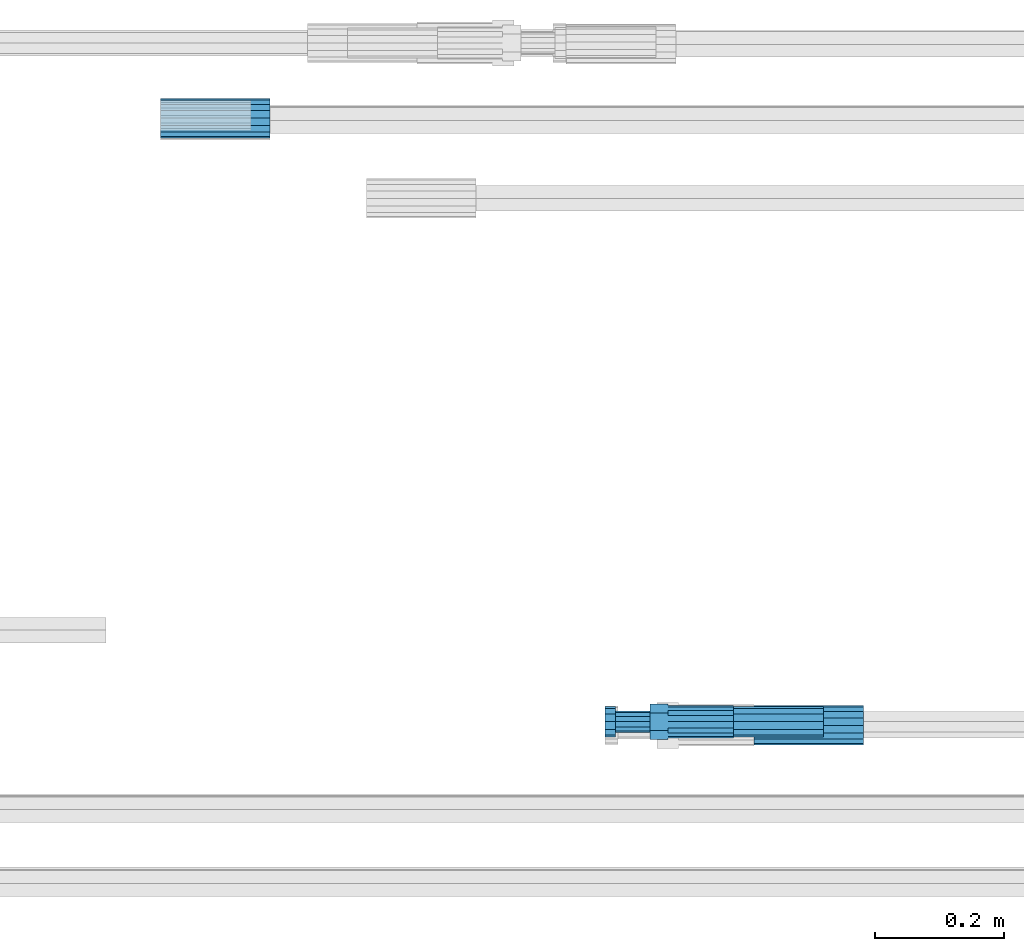
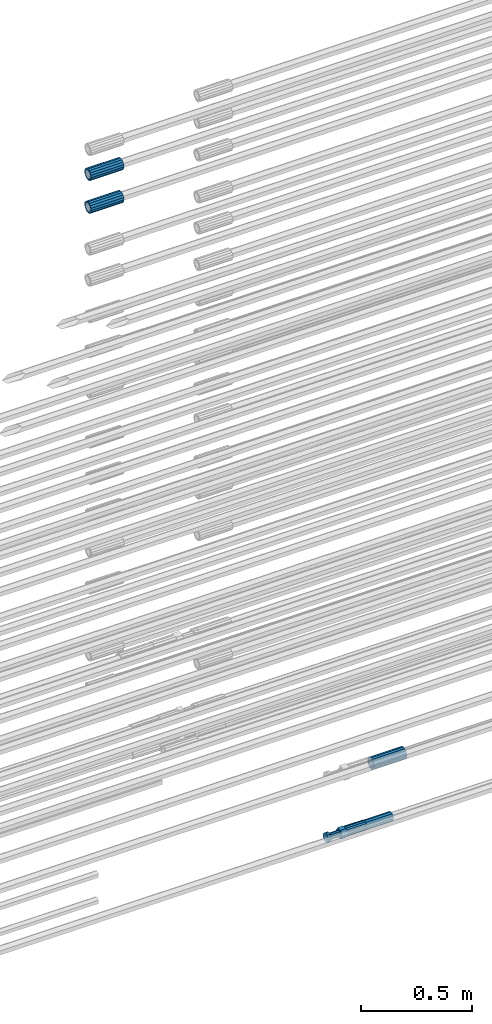
# One storey, part 10 of 119: 5 beams.
"""IFC2X3 building model written with IfcOpenShell, lengths in millimetres."""

from ifc_helpers import new_model, si_unit, frame, origin_with_axes, place, context, subcontext, project, spatial, faceted_brep, material, type_object, element, save


model = new_model("IFC2X3")

# Units and contexts
model_context = context("Model", 3, precision=1e-05, world=origin_with_axes())
body_context = subcontext(model_context, "Body", "Model", "MODEL_VIEW")
ifc_project = project(units=[si_unit("LENGTHUNIT", "METRE", prefix="MILLI"), si_unit("AREAUNIT", "SQUARE_METRE"), si_unit("VOLUMEUNIT", "CUBIC_METRE"), si_unit("MASSUNIT", "GRAM", prefix="KILO"), si_unit("TIMEUNIT", "SECOND"), si_unit("PLANEANGLEUNIT", "RADIAN"), si_unit("SOLIDANGLEUNIT", "STERADIAN"), si_unit("THERMODYNAMICTEMPERATUREUNIT", "DEGREE_CELSIUS"), si_unit("LUMINOUSINTENSITYUNIT", "LUMEN")], contexts=[model_context])

# Site, building, storey
site_placement = place(None, origin_with_axes())
site = spatial("IfcSite", under=ifc_project, at=site_placement, CompositionType="ELEMENT")
building_placement = place(site_placement, origin_with_axes())
building = spatial("IfcBuilding", under=site, at=building_placement, Name="Undefined", CompositionType="ELEMENT")
storey_placement = place(building_placement, origin_with_axes())
storey = spatial("IfcBuildingStorey", under=building, at=storey_placement, Name="Undefined", CompositionType="ELEMENT", Elevation=0.0)

# Beams
ifc_material = material(Name="STEEL/S275")
beam_type_1 = type_object("IfcBeamType", PredefinedType="NOTDEFINED")
beam_1_placement = place(storey_placement, frame((2032310.98007889, 6205343.08994599, 19244.4893122982), z_axis=(0.0, 0.0, 1.0), x_axis=(-0.99999999999998, 1.98000110685822e-07, 0.0)))
element("IfcBeam", 1, at=beam_1_placement, inside=storey, type_object=beam_type_1, material=ifc_material, Name="AG40N", context=body_context, shape_type="Brep", body=[
    faceted_brep([(1.62981450557709e-09, -23.4999999990687, 0.0), (7.45058059692383e-09, -21.7111690142192, 8.99306066057534), (170.000002125278, -21.711168999318, 8.99306066022245), (170.000002127141, -23.4999999844003, -3.66071617463604e-10), (4.65661287307739e-09, -16.6170093587134, 16.6170093578889), (170.000002122484, -16.6170093440451, 16.6170093575288), (1.86264514923096e-09, -8.99306066217832, 21.7111690140277), (170.000002118759, -8.99306064750999, 21.7111690136603), (2.3283064365387e-10, 9.31322574615479e-10, 23.5), (170.000002114102, 1.28056854009628e-08, 23.4999999996485), (-6.51925802230835e-09, 8.99306065868586, 21.7111690140241), (170.00000211224, 8.99306067335419, 21.7111690136639), (-7.45058059692383e-09, 16.6170093561523, 16.6170093578853), (170.000002109446, 16.6170093708206, 16.6170093575324), (-9.31322574615479e-09, 21.711169013055, 8.99306066057534), (170.000002108514, 21.7111690277234, 8.99306066022245), (-1.16415321826935e-09, 23.5000000009313, 0.0), (170.000002108514, 23.5000000144355, -3.66071617463604e-10), (-8.38190317153931e-09, 21.7111690151505, -8.99306066059444), (170.000002110377, 21.7111690300517, -8.9930606609546), (-5.58793544769287e-09, 16.6170093598776, -16.6170093579008), (170.000002113171, 16.6170093745459, -16.6170093582609), (-9.31322574615479e-10, 8.99306066334248, -21.7111690140396), (170.000002115965, 8.99306067801081, -21.7111690143961), (2.3283064365387e-10, 9.31322574615479e-10, -23.5), (170.00000211969, 1.7927959561348e-08, -23.5000000003843), (5.58793544769287e-09, -8.99306065752171, -21.7111690140396), (170.000002123415, -8.99306064285338, -21.7111690143961), (8.38190317153931e-09, -16.6170093549881, -16.6170093579008), (170.000002125278, -16.6170093403198, -16.6170093582646), (9.31322574615479e-09, -21.7111690121237, -8.99306066059444), (170.000002127141, -21.7111689972226, -8.9930606609546), (1.11758708953857e-08, -30.4999999990687, -9.54969436861575e-12), (1.30385160446167e-08, -28.1783257392235, -11.6718446871514), (170.000002129003, -28.1783257243223, -11.6718446875116), (170.000002129935, -30.4999999841675, -3.66071617463604e-10), (1.02445483207703e-08, -21.5667568228673, -21.5667568262129), (170.000002128072, -21.566756808199, -21.5667568265694), (7.45058059692383e-09, -11.6718446831219, -28.1783257416196), (170.000002125278, -11.6718446684536, -28.1783257419834), (3.72529029846191e-09, 3.95812094211578e-09, -30.5000000000277), (170.00000211969, 1.83936208486557e-08, -30.5000000003879), (-9.31322574615479e-10, 11.6718446905725, -28.1783257416232), (170.000002115965, 11.6718447052408, -28.1783257419797), (-6.51925802230835e-09, 21.5667568286881, -21.5667568262093), (170.000002110377, 21.5667568433564, -21.5667568265694), (-9.31322574615479e-09, 28.178325742716, -11.6718446871478), (170.000002108514, 28.1783257573843, -11.6718446875079), (-1.21071934700012e-08, 30.5, -5.91171556152403e-12), (170.000002106652, 30.5000000144355, -3.62433638656512e-10), (-1.21071934700012e-08, 28.1783257401548, 11.6718446871359), (170.00000210572, 28.1783257548232, 11.6718446867794), (-1.02445483207703e-08, 21.5667568240315, 21.5667568261974), (170.000002107583, 21.566756838467, 21.5667568258409), (-7.45058059692383e-09, 11.671844684286, 28.1783257416041), (170.000002110377, 11.6718446989544, 28.178325741244), (-2.79396772384644e-09, -2.56113708019257e-09, 30.5000000000159), (170.000002114102, 1.18743628263474e-08, 30.4999999996558), (1.86264514923096e-09, -11.6718446896411, 28.1783257416114), (170.000002118759, -11.67184467474, 28.178325741244), (7.45058059692383e-09, -21.5667568275239, 21.5667568261974), (170.000002123415, -21.5667568126228, 21.5667568258373), (1.02445483207703e-08, -28.1783257415518, 11.6718446871359), (170.000002127141, -28.1783257271163, 11.6718446867794)], [[[0, 1, 2, 3]], [[1, 4, 5, 2]], [[4, 6, 7, 5]], [[6, 8, 9, 7]], [[8, 10, 11, 9]], [[10, 12, 13, 11]], [[12, 14, 15, 13]], [[14, 16, 17, 15]], [[16, 18, 19, 17]], [[18, 20, 21, 19]], [[20, 22, 23, 21]], [[22, 24, 25, 23]], [[24, 26, 27, 25]], [[26, 28, 29, 27]], [[28, 30, 31, 29]], [[30, 0, 3, 31]], [[32, 33, 34, 35]], [[33, 36, 37, 34]], [[36, 38, 39, 37]], [[38, 40, 41, 39]], [[40, 42, 43, 41]], [[42, 44, 45, 43]], [[44, 46, 47, 45]], [[46, 48, 49, 47]], [[48, 50, 51, 49]], [[50, 52, 53, 51]], [[52, 54, 55, 53]], [[54, 56, 57, 55]], [[56, 58, 59, 57]], [[58, 60, 61, 59]], [[60, 62, 63, 61]], [[62, 32, 35, 63]], [[37, 39, 41, 43, 45, 47, 49, 51, 53, 55, 57, 59, 61, 63, 35, 34], [5, 7, 9, 11, 13, 15, 17, 19, 21, 23, 25, 27, 29, 31, 3, 2]], [[62, 60, 58, 56, 54, 52, 50, 48, 46, 44, 42, 40, 38, 36, 33, 32], [30, 28, 26, 24, 22, 20, 18, 16, 14, 12, 10, 8, 6, 4, 1, 0]]]),
])
beam_2_placement = place(storey_placement, frame((2031390.00007889, 6206285.47994599, 22039.9893062779), z_axis=(0.0, 0.0, 1.0), x_axis=(-0.99999999999998, 1.98000110685822e-07, 0.0)))
element("IfcBeam", 2, at=beam_2_placement, inside=storey, type_object=beam_type_1, material=ifc_material, Name="AG40N", context=body_context, shape_type="Brep", body=[
    faceted_brep([(1.62981450557709e-09, -23.4999999990687, 0.0), (7.45058059692383e-09, -21.7111690142192, 8.99306066057534), (170.000002125278, -21.711168999318, 8.99306066022245), (170.000002127141, -23.4999999844003, -3.66071617463604e-10), (4.65661287307739e-09, -16.6170093587134, 16.6170093578889), (170.000002122484, -16.6170093440451, 16.6170093575288), (1.86264514923096e-09, -8.99306066217832, 21.7111690140277), (170.000002118759, -8.99306064750999, 21.7111690136603), (2.3283064365387e-10, 9.31322574615479e-10, 23.5), (170.000002114102, 1.28056854009628e-08, 23.4999999996485), (-6.51925802230835e-09, 8.99306065868586, 21.7111690140241), (170.00000211224, 8.99306067335419, 21.7111690136639), (-7.45058059692383e-09, 16.6170093561523, 16.6170093578853), (170.000002109446, 16.6170093708206, 16.6170093575324), (-9.31322574615479e-09, 21.711169013055, 8.99306066057534), (170.000002108514, 21.7111690277234, 8.99306066022245), (-1.16415321826935e-09, 23.5000000009313, 0.0), (170.000002108514, 23.5000000144355, -3.66071617463604e-10), (-8.38190317153931e-09, 21.7111690151505, -8.99306066059444), (170.000002110377, 21.7111690300517, -8.9930606609546), (-5.58793544769287e-09, 16.6170093598776, -16.6170093579008), (170.000002113171, 16.6170093745459, -16.6170093582609), (-9.31322574615479e-10, 8.99306066334248, -21.7111690140396), (170.000002115965, 8.99306067801081, -21.7111690143961), (2.3283064365387e-10, 9.31322574615479e-10, -23.5), (170.00000211969, 1.7927959561348e-08, -23.5000000003843), (5.58793544769287e-09, -8.99306065752171, -21.7111690140396), (170.000002123415, -8.99306064285338, -21.7111690143961), (8.38190317153931e-09, -16.6170093549881, -16.6170093579008), (170.000002125278, -16.6170093403198, -16.6170093582646), (9.31322574615479e-09, -21.7111690121237, -8.99306066059444), (170.000002127141, -21.7111689972226, -8.9930606609546), (1.11758708953857e-08, -30.4999999990687, -9.54969436861575e-12), (1.30385160446167e-08, -28.1783257392235, -11.6718446871514), (170.000002129003, -28.1783257243223, -11.6718446875116), (170.000002129935, -30.4999999841675, -3.66071617463604e-10), (1.02445483207703e-08, -21.5667568228673, -21.5667568262129), (170.000002128072, -21.566756808199, -21.5667568265694), (7.45058059692383e-09, -11.6718446831219, -28.1783257416196), (170.000002125278, -11.6718446684536, -28.1783257419834), (3.72529029846191e-09, 3.95812094211578e-09, -30.5000000000277), (170.00000211969, 1.83936208486557e-08, -30.5000000003879), (-9.31322574615479e-10, 11.6718446905725, -28.1783257416232), (170.000002115965, 11.6718447052408, -28.1783257419797), (-6.51925802230835e-09, 21.5667568286881, -21.5667568262093), (170.000002110377, 21.5667568433564, -21.5667568265694), (-9.31322574615479e-09, 28.178325742716, -11.6718446871478), (170.000002108514, 28.1783257573843, -11.6718446875079), (-1.21071934700012e-08, 30.5, -5.91171556152403e-12), (170.000002106652, 30.5000000144355, -3.62433638656512e-10), (-1.21071934700012e-08, 28.1783257401548, 11.6718446871359), (170.00000210572, 28.1783257548232, 11.6718446867794), (-1.02445483207703e-08, 21.5667568240315, 21.5667568261974), (170.000002107583, 21.566756838467, 21.5667568258409), (-7.45058059692383e-09, 11.671844684286, 28.1783257416041), (170.000002110377, 11.6718446989544, 28.178325741244), (-2.79396772384644e-09, -2.56113708019257e-09, 30.5000000000159), (170.000002114102, 1.18743628263474e-08, 30.4999999996558), (1.86264514923096e-09, -11.6718446896411, 28.1783257416114), (170.000002118759, -11.67184467474, 28.178325741244), (7.45058059692383e-09, -21.5667568275239, 21.5667568261974), (170.000002123415, -21.5667568126228, 21.5667568258373), (1.02445483207703e-08, -28.1783257415518, 11.6718446871359), (170.000002127141, -28.1783257271163, 11.6718446867794)], [[[0, 1, 2, 3]], [[1, 4, 5, 2]], [[4, 6, 7, 5]], [[6, 8, 9, 7]], [[8, 10, 11, 9]], [[10, 12, 13, 11]], [[12, 14, 15, 13]], [[14, 16, 17, 15]], [[16, 18, 19, 17]], [[18, 20, 21, 19]], [[20, 22, 23, 21]], [[22, 24, 25, 23]], [[24, 26, 27, 25]], [[26, 28, 29, 27]], [[28, 30, 31, 29]], [[30, 0, 3, 31]], [[32, 33, 34, 35]], [[33, 36, 37, 34]], [[36, 38, 39, 37]], [[38, 40, 41, 39]], [[40, 42, 43, 41]], [[42, 44, 45, 43]], [[44, 46, 47, 45]], [[46, 48, 49, 47]], [[48, 50, 51, 49]], [[50, 52, 53, 51]], [[52, 54, 55, 53]], [[54, 56, 57, 55]], [[56, 58, 59, 57]], [[58, 60, 61, 59]], [[60, 62, 63, 61]], [[62, 32, 35, 63]], [[37, 39, 41, 43, 45, 47, 49, 51, 53, 55, 57, 59, 61, 63, 35, 34], [5, 7, 9, 11, 13, 15, 17, 19, 21, 23, 25, 27, 29, 31, 3, 2]], [[62, 60, 58, 56, 54, 52, 50, 48, 46, 44, 42, 40, 38, 36, 33, 32], [30, 28, 26, 24, 22, 20, 18, 16, 14, 12, 10, 8, 6, 4, 1, 0]]]),
])
beam_3_placement = place(storey_placement, frame((2031390.00007889, 6206285.48994599, 22219.9893062779), z_axis=(0.0, 0.0, 1.0), x_axis=(-0.99999999999998, 1.98000110685822e-07, 0.0)))
element("IfcBeam", 3, at=beam_3_placement, inside=storey, type_object=beam_type_1, material=ifc_material, Name="AG40N", context=body_context, shape_type="Brep", body=[
    faceted_brep([(1.62981450557709e-09, -23.4999999990687, 0.0), (7.45058059692383e-09, -21.7111690142192, 8.99306066057534), (170.000002125278, -21.711168999318, 8.99306066022245), (170.000002127141, -23.4999999844003, -3.66071617463604e-10), (4.65661287307739e-09, -16.6170093587134, 16.6170093578889), (170.000002122484, -16.6170093440451, 16.6170093575288), (1.86264514923096e-09, -8.99306066217832, 21.7111690140277), (170.000002118759, -8.99306064750999, 21.7111690136603), (2.3283064365387e-10, 9.31322574615479e-10, 23.5), (170.000002114102, 1.28056854009628e-08, 23.4999999996485), (-6.51925802230835e-09, 8.99306065868586, 21.7111690140241), (170.00000211224, 8.99306067335419, 21.7111690136639), (-7.45058059692383e-09, 16.6170093561523, 16.6170093578853), (170.000002109446, 16.6170093708206, 16.6170093575324), (-9.31322574615479e-09, 21.711169013055, 8.99306066057534), (170.000002108514, 21.7111690277234, 8.99306066022245), (-1.16415321826935e-09, 23.5000000009313, 0.0), (170.000002108514, 23.5000000144355, -3.66071617463604e-10), (-8.38190317153931e-09, 21.7111690151505, -8.99306066059444), (170.000002110377, 21.7111690300517, -8.9930606609546), (-5.58793544769287e-09, 16.6170093598776, -16.6170093579008), (170.000002113171, 16.6170093745459, -16.6170093582609), (-9.31322574615479e-10, 8.99306066334248, -21.7111690140396), (170.000002115965, 8.99306067801081, -21.7111690143961), (2.3283064365387e-10, 9.31322574615479e-10, -23.5), (170.00000211969, 1.7927959561348e-08, -23.5000000003843), (5.58793544769287e-09, -8.99306065752171, -21.7111690140396), (170.000002123415, -8.99306064285338, -21.7111690143961), (8.38190317153931e-09, -16.6170093549881, -16.6170093579008), (170.000002125278, -16.6170093403198, -16.6170093582646), (9.31322574615479e-09, -21.7111690121237, -8.99306066059444), (170.000002127141, -21.7111689972226, -8.9930606609546), (1.11758708953857e-08, -30.4999999990687, -9.54969436861575e-12), (1.30385160446167e-08, -28.1783257392235, -11.6718446871514), (170.000002129003, -28.1783257243223, -11.6718446875116), (170.000002129935, -30.4999999841675, -3.66071617463604e-10), (1.02445483207703e-08, -21.5667568228673, -21.5667568262129), (170.000002128072, -21.566756808199, -21.5667568265694), (7.45058059692383e-09, -11.6718446831219, -28.1783257416196), (170.000002125278, -11.6718446684536, -28.1783257419834), (3.72529029846191e-09, 3.95812094211578e-09, -30.5000000000277), (170.00000211969, 1.83936208486557e-08, -30.5000000003879), (-9.31322574615479e-10, 11.6718446905725, -28.1783257416232), (170.000002115965, 11.6718447052408, -28.1783257419797), (-6.51925802230835e-09, 21.5667568286881, -21.5667568262093), (170.000002110377, 21.5667568433564, -21.5667568265694), (-9.31322574615479e-09, 28.178325742716, -11.6718446871478), (170.000002108514, 28.1783257573843, -11.6718446875079), (-1.21071934700012e-08, 30.5, -5.91171556152403e-12), (170.000002106652, 30.5000000144355, -3.62433638656512e-10), (-1.21071934700012e-08, 28.1783257401548, 11.6718446871359), (170.00000210572, 28.1783257548232, 11.6718446867794), (-1.02445483207703e-08, 21.5667568240315, 21.5667568261974), (170.000002107583, 21.566756838467, 21.5667568258409), (-7.45058059692383e-09, 11.671844684286, 28.1783257416041), (170.000002110377, 11.6718446989544, 28.178325741244), (-2.79396772384644e-09, -2.56113708019257e-09, 30.5000000000159), (170.000002114102, 1.18743628263474e-08, 30.4999999996558), (1.86264514923096e-09, -11.6718446896411, 28.1783257416114), (170.000002118759, -11.67184467474, 28.178325741244), (7.45058059692383e-09, -21.5667568275239, 21.5667568261974), (170.000002123415, -21.5667568126228, 21.5667568258373), (1.02445483207703e-08, -28.1783257415518, 11.6718446871359), (170.000002127141, -28.1783257271163, 11.6718446867794)], [[[0, 1, 2, 3]], [[1, 4, 5, 2]], [[4, 6, 7, 5]], [[6, 8, 9, 7]], [[8, 10, 11, 9]], [[10, 12, 13, 11]], [[12, 14, 15, 13]], [[14, 16, 17, 15]], [[16, 18, 19, 17]], [[18, 20, 21, 19]], [[20, 22, 23, 21]], [[22, 24, 25, 23]], [[24, 26, 27, 25]], [[26, 28, 29, 27]], [[28, 30, 31, 29]], [[30, 0, 3, 31]], [[32, 33, 34, 35]], [[33, 36, 37, 34]], [[36, 38, 39, 37]], [[38, 40, 41, 39]], [[40, 42, 43, 41]], [[42, 44, 45, 43]], [[44, 46, 47, 45]], [[46, 48, 49, 47]], [[48, 50, 51, 49]], [[50, 52, 53, 51]], [[52, 54, 55, 53]], [[54, 56, 57, 55]], [[56, 58, 59, 57]], [[58, 60, 61, 59]], [[60, 62, 63, 61]], [[62, 32, 35, 63]], [[37, 39, 41, 43, 45, 47, 49, 51, 53, 55, 57, 59, 61, 63, 35, 34], [5, 7, 9, 11, 13, 15, 17, 19, 21, 23, 25, 27, 29, 31, 3, 2]], [[62, 60, 58, 56, 54, 52, 50, 48, 46, 44, 42, 40, 38, 36, 33, 32], [30, 28, 26, 24, 22, 20, 18, 16, 14, 12, 10, 8, 6, 4, 1, 0]]]),
])
beam_type_2 = type_object("IfcBeamType", PredefinedType="NOTDEFINED")
beam_4_placement = place(storey_placement, frame((2032249.00007889, 6205348.58994599, 18914.9893117151), z_axis=(0.0, 0.0, 1.0), x_axis=(-0.99999999999998, 1.98000110685822e-07, 0.0)))
element("IfcBeam", 4, at=beam_4_placement, inside=storey, type_object=beam_type_2, material=ifc_material, Name="AG32N", context=body_context, shape_type="Brep", body=[
    faceted_brep([(1.39698386192322e-09, -18.4999999990687, 0.0), (1.16415321826935e-09, -16.0214699693024, 9.25), (140.000000001164, -16.0214699935168, 9.25), (140.000000001397, -18.5000000232831, 0.0), (6.98491930961609e-10, -9.24999999906868, 16.0214699700118), (140.000000000698, -9.25000002328306, 16.0214699700118), (2.3283064365387e-10, 9.31322574615479e-10, 18.5), (140.000000000233, -2.3283064365387e-08, 18.5), (-2.3283064365387e-10, 9.25000000093132, 16.0214699700118), (139.999999999767, 9.24999997671694, 16.0214699700118), (-6.98491930961609e-10, 16.0214699711651, 9.25), (139.999999999302, 16.0214699469507, 9.25), (-9.31322574615479e-10, 18.5000000009313, 0.0), (139.999999999069, 18.4999999767169, 0.0), (-6.98491930961609e-10, 16.0214699711651, -9.25), (139.999999999302, 16.0214699469507, -9.25), (-2.3283064365387e-10, 9.25000000093132, -16.0214699700118), (139.999999999767, 9.24999997671694, -16.0214699700118), (2.3283064365387e-10, 9.31322574615479e-10, -18.5), (140.000000000233, -2.3283064365387e-08, -18.5), (6.98491930961609e-10, -9.24999999906868, -16.0214699700118), (140.000000000698, -9.25000002328306, -16.0214699700118), (1.16415321826935e-09, -16.0214699693024, -9.25), (140.000000001164, -16.0214699935168, -9.25), (1.62981450557709e-09, -23.4999999990687, 0.0), (1.39698386192322e-09, -20.3515969878063, -11.75), (140.000000001397, -20.3515970120206, -11.75), (140.00000000163, -23.5000000232831, 0.0), (9.31322574615479e-10, -11.7499999990687, -20.351596988934), (140.000000000931, -11.7500000232831, -20.351596988934), (2.3283064365387e-10, 9.31322574615479e-10, -23.5), (140.000000000233, -2.3283064365387e-08, -23.5), (-4.65661287307739e-10, 11.7500000009313, -20.351596988934), (139.999999999534, 11.7499999767169, -20.351596988934), (-9.31322574615479e-10, 20.3515969896689, -11.75), (139.999999999069, 20.3515969654545, -11.75), (-1.16415321826935e-09, 23.5000000009313, 0.0), (139.999999998836, 23.4999999767169, 0.0), (-9.31322574615479e-10, 20.3515969896689, 11.75), (139.999999999069, 20.3515969654545, 11.75), (-4.65661287307739e-10, 11.7500000009313, 20.351596988934), (139.999999999534, 11.7499999767169, 20.351596988934), (2.3283064365387e-10, 9.31322574615479e-10, 23.5), (140.000000000233, -2.3283064365387e-08, 23.5), (9.31322574615479e-10, -11.7499999990687, 20.351596988934), (140.000000000931, -11.7500000232831, 20.351596988934), (1.39698386192322e-09, -20.3515969878063, 11.75), (140.000000001397, -20.3515970120206, 11.75)], [[[0, 1, 2, 3]], [[1, 4, 5, 2]], [[4, 6, 7, 5]], [[6, 8, 9, 7]], [[8, 10, 11, 9]], [[10, 12, 13, 11]], [[12, 14, 15, 13]], [[14, 16, 17, 15]], [[16, 18, 19, 17]], [[18, 20, 21, 19]], [[20, 22, 23, 21]], [[22, 0, 3, 23]], [[24, 25, 26, 27]], [[25, 28, 29, 26]], [[28, 30, 31, 29]], [[30, 32, 33, 31]], [[32, 34, 35, 33]], [[34, 36, 37, 35]], [[36, 38, 39, 37]], [[38, 40, 41, 39]], [[40, 42, 43, 41]], [[42, 44, 45, 43]], [[44, 46, 47, 45]], [[46, 24, 27, 47]], [[29, 31, 33, 35, 37, 39, 41, 43, 45, 47, 27, 26], [5, 7, 9, 11, 13, 15, 17, 19, 21, 23, 3, 2]], [[46, 44, 42, 40, 38, 36, 34, 32, 30, 28, 25, 24], [22, 20, 18, 16, 14, 12, 10, 8, 6, 4, 1, 0]]]),
])
beam_type_3 = type_object("IfcBeamType", Name="ROD50", PredefinedType="NOTDEFINED")
beam_5_placement = place(storey_placement, frame((2032109.00007889, 6205348.58994599, 18914.9893066751), z_axis=(0.0, 0.0, 1.0), x_axis=(-0.99999999999998, 1.98000110685822e-07, 0.0)))
element("IfcBeam", 5, at=beam_5_placement, inside=storey, type_object=beam_type_3, material=ifc_material, Name="AGB32", ObjectType="ROD50", context=body_context, shape_type="Brep", body=[
    faceted_brep([(100.999999995111, 13.8425000002608, 23.9759132212093), (100.999999996508, 17.5285119004548, 17.5915533324223), (100.999999997672, 9.56708580907434, 23.0969883129546), (100.999999995111, 5.14843190740794, 23.9759132212093), (100.999999995111, -13.8425000002608, 23.9759132212093), (129.099999995669, -13.8425000002608, 23.9759132182917), (129.099999995669, 13.8425000002608, 23.9759132182917), (100.999999995111, -5.14843190740794, 23.9759132212093), (100.999999996508, -17.5285119004548, 17.5915533324223), (100.999999997672, -9.56708580907434, 23.0969883129546), (101.000000000233, -27.6849999995902, -8.25639290269464e-08), (129.100000000792, -27.6849999995902, -8.5481588030234e-08), (100.999999998836, -23.5887256683782, 7.09495518143376), (101.00000000163, -23.5887256180868, -7.09495543353478), (101.000000000233, -25.0, 1.70985003933311e-10), (101.000000005355, -13.8425000002608, -23.9759133863372), (129.100000005914, -13.8425000002608, -23.9759133892549), (101.000000003958, -17.5285119721666, -17.5915533734478), (101.000000005355, -5.14843107573688, -23.9759133863372), (101.000000002561, -9.56708580907434, -23.0969883126127), (101.000000005355, 13.8425000002608, -23.9759133863372), (129.100000005914, 13.8425000002608, -23.9759133892549), (101.000000005355, 5.14843107573688, -23.9759133863372), (101.000000002561, 9.56708580907434, -23.0969883126127), (101.000000003958, 17.5285119721666, -17.5915533734478), (101.000000000233, 27.6849999995902, -8.25639290269464e-08), (129.100000000792, 27.6849999995902, -8.5481588030234e-08), (101.00000000163, 23.5887256180868, -7.09495543353478), (101.000000000233, 25.0, 1.70985003933311e-10), (100.999999998836, 23.5887256683782, 7.09495518143376), (-6.98491930961609e-10, -23.0969883129001, 9.56708580912891), (-1.62981450557709e-09, -17.6776695298031, 17.6776695296649), (-2.3283064365387e-09, -9.56708580907434, 23.0969883127837), (-2.56113708019257e-09, 0.0, 25.0), (-2.3283064365387e-09, 9.56708580907434, 23.0969883127837), (-1.62981450557709e-09, 17.6776695298031, 17.6776695296649), (-6.98491930961609e-10, 23.0969883129001, 9.56708580912891), (2.3283064365387e-10, 25.0, 0.0), (1.16415321826935e-09, 23.0969883129001, -9.56708580912891), (2.09547579288483e-09, 17.6776695298031, -17.6776695296649), (2.56113708019257e-09, 9.56708580907434, -23.0969883127837), (2.79396772384644e-09, 0.0, -25.0), (2.56113708019257e-09, -9.56708580907434, -23.0969883127837), (2.09547579288483e-09, -17.6776695298031, -17.6776695296649), (1.16415321826935e-09, -23.0969883129001, -9.56708580912891), (2.3283064365387e-10, -25.0, 0.0), (100.999999999302, 23.0969883129001, 9.5670858092999), (101.000000001164, 23.0969883129001, -9.56708580895793), (101.000000002794, 0.0, -24.999999999829), (101.000000001164, -23.0969883129001, -9.56708580895793), (100.999999999302, -23.0969883129001, 9.5670858092999), (100.999999997439, 0.0, 25.000000000171), (129.49999999837, -14.2894191620871, 8.24999989414209), (129.499999996973, -8.25, 14.2894190565821), (129.49999999674, 0.0, 16.4999998941421), (129.499999996973, 8.25, 14.2894190565821), (129.49999999837, 14.2894191620871, 8.24999989414209), (129.500000000233, 16.5, -1.05857907328755e-07), (129.500000002095, 14.2894191620871, -8.25000010585791), (129.50000000326, 8.25, -14.2894192683016), (129.500000003492, 0.0, -16.5000001058615), (129.50000000326, -8.25, -14.2894192683016), (129.500000002095, -14.2894191620871, -8.25000010586155), (129.500000000233, -16.5, -1.05857907328755e-07), (182.499999996973, 8.25, 14.2894190510815), (182.49999999674, 0.0, 16.4999998886415), (182.49999999837, 14.2894191620871, 8.24999988864147), (182.500000000233, 16.5, -1.11358531285077e-07), (182.500000002095, 14.2894191620871, -8.25000011135853), (182.50000000326, 8.25, -14.2894192738022), (182.500000003492, 0.0, -16.5000001113622), (182.50000000326, -8.25, -14.2894192738022), (182.500000002095, -14.2894191620871, -8.25000011136217), (182.500000000233, -16.5, -1.11358531285077e-07), (182.49999999837, -14.2894191620871, 8.24999988864147), (182.499999996973, -8.25, 14.2894190510815), (182.500000002561, -20.7846096912399, -12.0000001491826), (182.500000004657, -12.0, -20.7846098400078), (199.000000004657, -12.0, -20.7846098417212), (199.000000002561, -20.7846096912399, -12.0000001508961), (182.500000005355, 0.0, -24.0000001491826), (199.000000005355, 0.0, -24.0000001508961), (182.500000004657, 12.0, -20.7846098400078), (199.000000004657, 12.0, -20.7846098417212), (182.500000002561, 20.7846096912399, -12.000000149179), (199.000000002561, 20.7846096912399, -12.0000001508924), (182.500000000233, 24.0, -1.49178958963603e-07), (199.000000000233, 24.0, -1.50892446981743e-07), (182.499999997672, 20.7846096912399, 11.999999850821), (198.999999997672, 20.7846096912399, 11.9999998491076), (182.499999995809, 12.0, 20.7846095416462), (198.999999995809, 12.0, 20.7846095399327), (182.499999995111, 0.0, 23.999999850821), (198.999999995111, 0.0, 23.9999998491076), (182.499999995809, -12.0, 20.7846095416462), (198.999999995809, -12.0, 20.7846095399327), (182.499999997672, -20.7846096912399, 11.999999850821), (198.999999997672, -20.7846096912399, 11.9999998491039), (182.500000000233, -24.0, -1.49178958963603e-07), (199.000000000233, -24.0, -1.50892446981743e-07)], [[[0, 1, 2, 3]], [[4, 5, 6, 0, 3, 7]], [[8, 4, 7, 9]], [[10, 11, 5, 4, 8, 12]], [[13, 10, 12, 14]], [[15, 16, 11, 10, 13, 17]], [[18, 15, 17, 19]], [[20, 21, 16, 15, 18, 22]], [[20, 22, 23, 24]], [[25, 26, 21, 20, 24, 27]], [[25, 27, 28, 29]], [[30, 31, 32, 33, 34, 35, 36, 37, 38, 39, 40, 41, 42, 43, 44, 45]], [[28, 37, 36, 46, 29]], [[27, 47, 38, 37, 28]], [[24, 47, 27]], [[39, 38, 47, 24]], [[23, 40, 39, 24]], [[22, 48, 41, 40, 23]], [[18, 48, 22]], [[19, 42, 41, 48, 18]], [[17, 43, 42, 19]], [[44, 43, 17, 49]], [[13, 49, 17]], [[14, 45, 44, 49, 13]], [[12, 50, 30, 45, 14]], [[8, 50, 12]], [[31, 30, 50, 8]], [[9, 32, 31, 8]], [[7, 51, 33, 32, 9]], [[3, 51, 7]], [[2, 34, 33, 51, 3]], [[1, 35, 34, 2]], [[36, 35, 1, 46]], [[29, 46, 1]], [[0, 6, 26, 25, 29, 1]], [[5, 11, 16, 21, 26, 6]], [[52, 53, 54, 55, 56, 57, 58, 59, 60, 61, 62, 63]], [[64, 55, 54, 65]], [[66, 56, 55, 64]], [[67, 57, 56, 66]], [[68, 58, 57, 67]], [[69, 59, 58, 68]], [[70, 60, 59, 69]], [[71, 61, 60, 70]], [[72, 62, 61, 71]], [[73, 63, 62, 72]], [[74, 52, 63, 73]], [[75, 53, 52, 74]], [[65, 54, 53, 75]], [[76, 77, 78, 79]], [[77, 80, 81, 78]], [[80, 82, 83, 81]], [[82, 84, 85, 83]], [[84, 86, 87, 85]], [[86, 88, 89, 87]], [[88, 90, 91, 89]], [[90, 92, 93, 91]], [[92, 94, 95, 93]], [[94, 96, 97, 95]], [[96, 98, 99, 97]], [[78, 81, 83, 85, 87, 89, 91, 93, 95, 97, 99, 79]], [[98, 76, 79, 99]], [[96, 94, 92, 90, 88, 86, 84, 82, 80, 77, 76, 98], [74, 73, 72, 71, 70, 69, 68, 67, 66, 64, 65, 75]]]),
])

save(model, "model.ifc")
